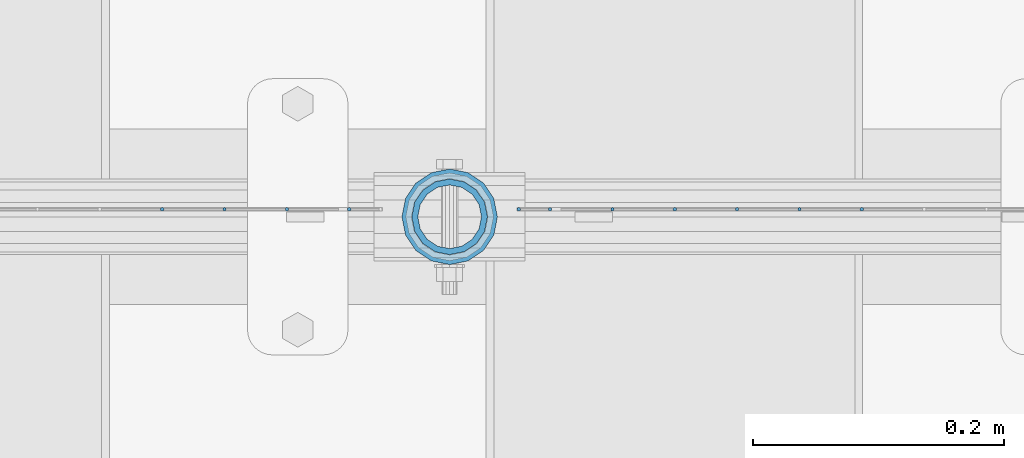
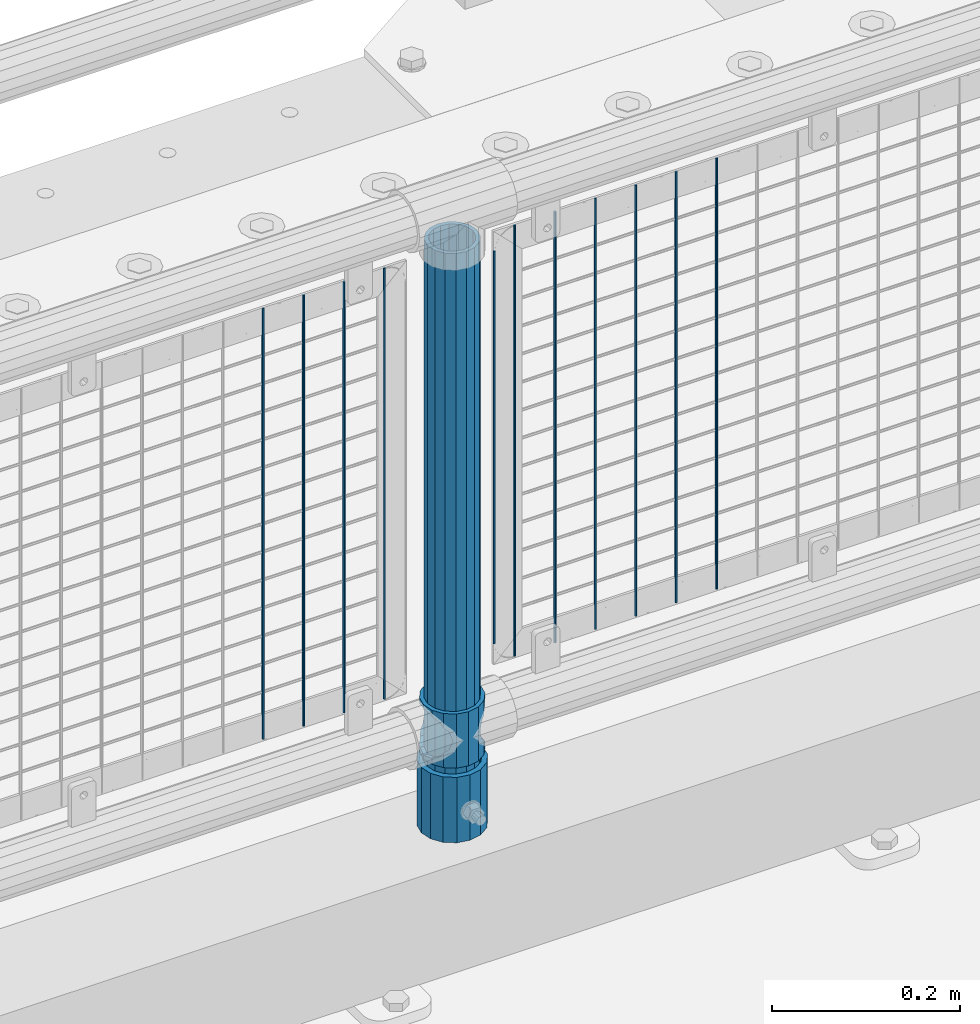
# One storey, part 85 of 247: 14 columns.
"""IFC2X3 building model written with IfcOpenShell, lengths in millimetres."""

import ifcopenshell
import ifcopenshell.guid

model = None  # the IFC model being written
_history = None  # IfcOwnerHistory: only IFC2X3 demands one
_inside = {}  # id of a spatial element -> (the spatial element, [elements in it])
_under = {}  # id of a project, library or spatial element -> (it, [spatial elements below it])
_declared = {}  # id of a project -> (the project, [libraries it declares])
_typed = {}  # id of a type object -> (the type object, [elements of that type])
_made_of = {}  # id of a material, layer set ... -> (it, [elements and type objects made of it])


def new_model(schema):
    """Start an empty IFC model of exactly this schema.

    Asked for "IFC4X3", IfcOpenShell would pick the latest addendum, in which some entities
    have other attributes; the version numbers below select the first issue.
    IFC2X3 requires an IfcOwnerHistory on every rooted entity: one is made here for all.
    """
    global model, _history
    if schema == "IFC4X3":
        model = ifcopenshell.file(schema_version=(4, 3, 0, 0))
    else:
        model = ifcopenshell.file(schema=schema)
    _inside.clear()
    _under.clear()
    _declared.clear()
    _typed.clear()
    _made_of.clear()
    _history = None
    if model.schema == "IFC2X3":
        org = make("IfcOrganization", Name="unknown")
        user = make(
            "IfcPersonAndOrganization",
            ThePerson=make("IfcPerson", FamilyName="unknown"),
            TheOrganization=org,
        )
        app = make(
            "IfcApplication",
            ApplicationDeveloper=org,
            Version="unknown",
            ApplicationFullName="unknown",
            ApplicationIdentifier="unknown",
        )
        _history = make(
            "IfcOwnerHistory",
            OwningUser=user,
            OwningApplication=app,
            ChangeAction="ADDED",
            CreationDate=0,
        )
    return model


def make(cls, **values):
    """One entity of the class cls with the attributes given. An attribute that is None is left unset."""
    return model.create_entity(
        cls, **{name: value for name, value in values.items() if value is not None}
    )


def rooted(cls, **values):
    """An entity with a GlobalId (a new one), such as an element, a storey or a relation."""
    return make(cls, GlobalId=ifcopenshell.guid.new(), OwnerHistory=_history, **values)


def si_unit(unit_type, name, prefix=None):
    """IfcSIUnit, for example si_unit("LENGTHUNIT", "METRE", prefix="MILLI")."""
    return make("IfcSIUnit", UnitType=unit_type, Prefix=prefix, Name=name)


def assignment(units):
    """IfcUnitAssignment: the units of a project."""
    return None if units is None else make("IfcUnitAssignment", Units=units)


def point(xyz):
    """IfcCartesianPoint."""
    return None if xyz is None else make("IfcCartesianPoint", Coordinates=xyz)


def direction(xyz):
    """IfcDirection."""
    return None if xyz is None else make("IfcDirection", DirectionRatios=xyz)


def frame(location, z_axis=None, x_axis=None):
    """IfcAxis2Placement3D, a coordinate frame: its origin and axes. An axis left out is left unset."""
    return make(
        "IfcAxis2Placement3D",
        Location=point(location),
        Axis=direction(z_axis),
        RefDirection=direction(x_axis),
    )


def origin_with_axes():
    """The frame at (0, 0, 0) with the z axis (0, 0, 1) and the x axis (1, 0, 0) written out."""
    return frame((0.0, 0.0, 0.0), z_axis=(0.0, 0.0, 1.0), x_axis=(1.0, 0.0, 0.0))


def place(relative_to, where):
    """IfcLocalPlacement: puts the frame where relative to a parent placement (None: the world)."""
    return make(
        "IfcLocalPlacement", PlacementRelTo=relative_to, RelativePlacement=where
    )


def context(
    kind, dimensions, precision=None, world=None, true_north=None, identifier=None
):
    """IfcGeometricRepresentationContext, for example the 3D "Model" context."""
    return make(
        "IfcGeometricRepresentationContext",
        ContextIdentifier=identifier,
        ContextType=kind,
        CoordinateSpaceDimension=dimensions,
        Precision=precision,
        WorldCoordinateSystem=world,
        TrueNorth=true_north,
    )


def subcontext(parent, identifier, kind, view, scale=None):
    """IfcGeometricRepresentationSubContext, for example "Body" below "Model"."""
    return make(
        "IfcGeometricRepresentationSubContext",
        ContextIdentifier=identifier,
        ContextType=kind,
        ParentContext=parent,
        TargetScale=scale,
        TargetView=view,
    )


def project(units=None, contexts=None):
    """IfcProject with its units and contexts."""
    return rooted(
        "IfcProject",
        Name="project",
        RepresentationContexts=contexts,
        UnitsInContext=assignment(units),
    )


def spatial(cls, under=None, at=None, **own):
    """A site, building, storey or space (cls), placed at a placement, below another one or the project."""
    s = rooted(cls, ObjectPlacement=at, **own)
    if under is not None:
        _under.setdefault(under.id(), (under, []))[1].append(s)
    return s


def faces_of(points, faces, orient=None, outer=None):
    """IfcFace entities. A face is a list of loops; a loop is a list of indices into points, from 0.

    orient and outer hold one flag for each loop. By default every Orientation is true, the
    first loop of a face is its IfcFaceOuterBound and the others are IfcFaceBound.
    """
    made = []
    for i, loops in enumerate(faces):
        bounds = []
        for j, loop in enumerate(loops):
            is_outer = j == 0 if outer is None else outer[i][j]
            bounds.append(
                make(
                    "IfcFaceOuterBound" if is_outer else "IfcFaceBound",
                    Bound=make("IfcPolyLoop", Polygon=[points[k] for k in loop]),
                    Orientation=True if orient is None else orient[i][j],
                )
            )
        made.append(make("IfcFace", Bounds=bounds))
    return made


def faceted_brep(points, faces, orient=None, outer=None, voids=None):
    """IfcFacetedBrep: a solid bounded by flat faces; with voids (closed shells), ...WithVoids."""
    shared = [point(p) for p in points]
    hull = make("IfcClosedShell", CfsFaces=faces_of(shared, faces, orient, outer))
    if voids is None:
        return make("IfcFacetedBrep", Outer=hull)
    return make(
        "IfcFacetedBrepWithVoids",
        Outer=hull,
        Voids=[
            make(cls, CfsFaces=faces_of(shared, fs, o, b)) for cls, fs, o, b in voids
        ],
    )


def shape(context_of_items, identifier, shape_type, items):
    """IfcShapeRepresentation: the items that make up one representation, for example the "Body"."""
    return make(
        "IfcShapeRepresentation",
        ContextOfItems=context_of_items,
        RepresentationIdentifier=identifier,
        RepresentationType=shape_type,
        Items=items,
    )


def material(Name=None, Category=None):
    """IfcMaterial."""
    return make("IfcMaterial", Name=Name, Category=Category)


def made_of(thing, what):
    """Note that an element or type object is made of a material, layer set ...; save() writes the relation."""
    if what is not None:
        _made_of.setdefault(what.id(), (what, []))[1].append(thing)
    return thing


def type_object(cls, material=None, **own):
    """A type object (cls), such as IfcWallType, which elements share."""
    return made_of(rooted(cls, **own), material)


def element(
    cls,
    number,
    at=None,
    inside=None,
    cuts=None,
    type_object=None,
    material=None,
    context=None,
    identifier="Body",
    shape_type=None,
    held_by="IfcProductDefinitionShape",
    body=None,
    shapes=None,
    **own,
):
    """One element of the class cls, such as IfcWall. Its Tag is "e" and its number.

    at: its placement. inside: the storey or other place that contains it. cuts: it is an
    opening in that element (IfcRelVoidsElement). A single representation is given by context,
    identifier, shape_type and body (its items); several are given by shapes. held_by: the class
    of the entity that holds the representations. save() writes the other relations.
    """
    e = rooted(cls, Tag="e%d" % number, ObjectPlacement=at, **own)
    if body is not None:
        shapes = [shape(context, identifier, shape_type, body)]
    if shapes is not None:
        e.Representation = make(held_by, Representations=shapes)
    if inside is not None:
        _inside.setdefault(inside.id(), (inside, []))[1].append(e)
    if cuts is not None:
        rooted(
            "IfcRelVoidsElement", RelatingBuildingElement=cuts, RelatedOpeningElement=e
        )
    if type_object is not None:
        _typed.setdefault(type_object.id(), (type_object, []))[1].append(e)
    return made_of(e, material)


def aggregate(whole, parts):
    """IfcRelAggregates: a whole, such as a stair, and the parts it consists of."""
    return rooted("IfcRelAggregates", RelatingObject=whole, RelatedObjects=parts)


def save(model, path):
    """Write the relations noted so far, then the file.

    IfcRelAggregates (storeys below a building ...), IfcRelContainedInSpatialStructure (elements
    in a storey), IfcRelDefinesByType, IfcRelAssociatesMaterial and IfcRelDeclares: one each for
    every whole, place, type object, material and project.
    """
    for whole, parts in _under.values():
        aggregate(whole, parts)
    for where, things in _inside.values():
        rooted(
            "IfcRelContainedInSpatialStructure",
            RelatedElements=things,
            RelatingStructure=where,
        )
    for kind, things in _typed.values():
        rooted("IfcRelDefinesByType", RelatedObjects=things, RelatingType=kind)
    for what, things in _made_of.values():
        rooted("IfcRelAssociatesMaterial", RelatedObjects=things, RelatingMaterial=what)
    for by, libraries in _declared.values():
        rooted("IfcRelDeclares", RelatingContext=by, RelatedDefinitions=libraries)
    model.write(path)


model = new_model("IFC2X3")

# Units and contexts
model_context = context("Model", 3, precision=1e-05, world=origin_with_axes())
body_context = subcontext(model_context, "Body", "Model", "MODEL_VIEW")
ifc_project = project(units=[si_unit("LENGTHUNIT", "METRE", prefix="MILLI"), si_unit("AREAUNIT", "SQUARE_METRE"), si_unit("VOLUMEUNIT", "CUBIC_METRE"), si_unit("MASSUNIT", "GRAM", prefix="KILO"), si_unit("TIMEUNIT", "SECOND"), si_unit("PLANEANGLEUNIT", "RADIAN"), si_unit("SOLIDANGLEUNIT", "STERADIAN"), si_unit("THERMODYNAMICTEMPERATUREUNIT", "DEGREE_CELSIUS"), si_unit("LUMINOUSINTENSITYUNIT", "LUMEN")], contexts=[model_context])

# Site, building, storey
site_placement = place(None, origin_with_axes())
site = spatial("IfcSite", under=ifc_project, at=site_placement, CompositionType="ELEMENT")
building_placement = place(site_placement, origin_with_axes())
building = spatial("IfcBuilding", under=site, at=building_placement, Name="Standard", CompositionType="ELEMENT")
storey_placement = place(building_placement, origin_with_axes())
storey = spatial("IfcBuildingStorey", under=building, at=storey_placement, Name="Undefined", CompositionType="ELEMENT", Elevation=0.0)

# Columns
ifc_material_1 = material()
column_type_1 = type_object("IfcColumnType", PredefinedType="NOTDEFINED")
column_1_placement = place(storey_placement, frame((8621.0, 7664.5, 168.02), z_axis=(0.0, 1.0, 0.0), x_axis=(0.0, 0.0, 1.0)))
element("IfcColumn", 1, at=column_1_placement, inside=storey, type_object=column_type_1, material=ifc_material_1, context=body_context, shape_type="Brep", body=[
    faceted_brep([(0.0, -31.75, 0.0), (0.0, -29.3331751572332, 12.1501989775916), (85.0, -29.3331751572332, 12.1501989775916), (85.0, -31.75, 0.0), (0.0, -22.4506403026735, 22.4506403026726), (85.0, -22.4506403026735, 22.4506403026726), (0.0, -12.1501989775916, 29.3331751572332), (85.0, -12.1501989775916, 29.3331751572332), (0.0, 0.0, 31.75), (85.0, 0.0, 31.75), (0.0, 12.1501989775916, 29.3331751572332), (85.0, 12.1501989775916, 29.3331751572332), (0.0, 22.4506403026735, 22.4506403026726), (85.0, 22.4506403026735, 22.4506403026726), (0.0, 29.3331751572332, 12.1501989775916), (85.0, 29.3331751572332, 12.1501989775916), (0.0, 31.75, 0.0), (85.0, 31.75, 0.0), (0.0, 29.3331751572332, -12.1501989775916), (85.0, 29.3331751572332, -12.1501989775916), (0.0, 22.4506403026735, -22.4506403026726), (85.0, 22.4506403026735, -22.4506403026726), (0.0, 12.1501989775916, -29.3331751572332), (85.0, 12.1501989775916, -29.3331751572332), (0.0, 0.0, -31.75), (85.0, 0.0, -31.75), (0.0, -12.1501989775916, -29.3331751572332), (85.0, -12.1501989775916, -29.3331751572332), (0.0, -22.4506403026735, -22.4506403026726), (85.0, -22.4506403026735, -22.4506403026726), (0.0, -29.3331751572332, -12.1501989775916), (85.0, -29.3331751572332, -12.1501989775916), (0.0, -38.0499999999993, 0.0), (0.0, -35.1536162120537, -14.5611046014919), (85.0, -35.1536162120537, -14.5611046014919), (85.0, -38.0499999999993, 0.0), (0.0, -26.9054130241475, -26.9054130241484), (85.0, -26.9054130241475, -26.9054130241484), (0.0, -14.561104601491, -35.1536162120547), (85.0, -14.561104601491, -35.1536162120547), (0.0, 0.0, -38.0500000000002), (85.0, 0.0, -38.0500000000002), (0.0, 14.561104601491, -35.1536162120547), (85.0, 14.561104601491, -35.1536162120547), (0.0, 26.9054130241475, -26.9054130241484), (85.0, 26.9054130241475, -26.9054130241484), (0.0, 35.1536162120537, -14.5611046014919), (85.0, 35.1536162120537, -14.5611046014919), (0.0, 38.0499999999993, 0.0), (85.0, 38.0499999999993, 0.0), (0.0, 35.1536162120537, 14.5611046014919), (85.0, 35.1536162120537, 14.5611046014919), (0.0, 26.9054130241475, 26.9054130241484), (85.0, 26.9054130241475, 26.9054130241484), (0.0, 14.561104601491, 35.1536162120547), (85.0, 14.561104601491, 35.1536162120547), (0.0, 0.0, 38.0500000000002), (85.0, 0.0, 38.0500000000002), (0.0, -14.561104601491, 35.1536162120547), (85.0, -14.561104601491, 35.1536162120547), (0.0, -26.9054130241475, 26.9054130241484), (85.0, -26.9054130241475, 26.9054130241484), (0.0, -35.1536162120537, 14.5611046014919), (85.0, -35.1536162120537, 14.5611046014919)], [[[0, 1, 2, 3]], [[1, 4, 5, 2]], [[4, 6, 7, 5]], [[6, 8, 9, 7]], [[8, 10, 11, 9]], [[10, 12, 13, 11]], [[12, 14, 15, 13]], [[14, 16, 17, 15]], [[16, 18, 19, 17]], [[18, 20, 21, 19]], [[20, 22, 23, 21]], [[22, 24, 25, 23]], [[24, 26, 27, 25]], [[26, 28, 29, 27]], [[28, 30, 31, 29]], [[30, 0, 3, 31]], [[32, 33, 34, 35]], [[33, 36, 37, 34]], [[36, 38, 39, 37]], [[38, 40, 41, 39]], [[40, 42, 43, 41]], [[42, 44, 45, 43]], [[44, 46, 47, 45]], [[46, 48, 49, 47]], [[48, 50, 51, 49]], [[50, 52, 53, 51]], [[52, 54, 55, 53]], [[54, 56, 57, 55]], [[56, 58, 59, 57]], [[58, 60, 61, 59]], [[60, 62, 63, 61]], [[62, 32, 35, 63]], [[37, 39, 41, 43, 45, 47, 49, 51, 53, 55, 57, 59, 61, 63, 35, 34], [5, 7, 9, 11, 13, 15, 17, 19, 21, 23, 25, 27, 29, 31, 3, 2]], [[62, 60, 58, 56, 54, 52, 50, 48, 46, 44, 42, 40, 38, 36, 33, 32], [30, 28, 26, 24, 22, 20, 18, 16, 14, 12, 10, 8, 6, 4, 1, 0]]]),
])
ifc_material_2 = material(Name="Misc_Undefined")
column_type_2 = type_object("IfcColumnType", PredefinedType="NOTDEFINED")
column_2_placement = place(storey_placement, frame((8621.0, 7664.5, 263.02), z_axis=(-1.0, 0.0, 0.0), x_axis=(0.0, 0.0, 1.0)))
element("IfcColumn", 2, at=column_2_placement, inside=storey, type_object=column_type_2, material=ifc_material_2, context=body_context, shape_type="Brep", body=[
    faceted_brep([(56.6106908090114, 21.4606908090118, -21.4606908090118), (56.6106908090114, 21.4606908090118, -27.1226768591096), (61.9623795176755, 13.4513226476329, -32.4743655677721), (63.1897438117172, 11.6144421722802, -32.839743811719), (63.1897438117172, 11.6144421722802, -28.0397438117179), (46.7644421722801, 28.0397438117179, -11.6144421722802), (46.7644421722801, 28.0397438117179, -20.088203122983), (51.5310424080055, 24.8548033587067, -24.8548033587067), (35.1499999999996, 30.35, 0.0), (35.1499999999996, 30.3500000000004, -16.6306603983649), (23.5355578277192, 28.0397438117179, -11.6144421722802), (23.5355578277192, 28.0397438117179, -20.088203122983), (13.6893091909879, 21.4606908090118, -21.4606908090118), (13.6893091909879, 21.4606908090118, -27.1226768591096), (18.768957591997, 24.8548033587067, -24.8548033587067), (7.11025618828211, 11.6144421722802, -28.0397438117179), (7.11025618828211, 11.6144421722802, -32.839743811719), (8.33762048232387, 13.4513226476329, -32.4743655677721), (4.79999999999961, 0.0, -30.3500000000004), (4.79999999999961, 0.0, -35.1499999999996), (7.11025618828211, -11.6144421722802, -28.0397438117179), (7.11025618828211, -11.6144421722802, -32.839743811719), (13.6893091909879, -21.4606908090118, -21.4606908090118), (13.6893091909879, -21.4606908090118, -27.1226768591077), (8.33762048232325, -13.4513226476329, -32.4743655677721), (23.5355578277191, -28.0397438117179, -11.6144421722802), (23.5355578277191, -28.0397438117179, -20.0882031229885), (18.768957591997, -24.8548033587067, -24.8548033587067), (35.1499999999996, -30.35, 0.0), (35.1499999999996, -30.3500000000004, -16.6306603983739), (46.7644421722801, -28.0397438117179, -11.6144421722802), (46.7644421722801, -28.0397438117179, -20.0882031229885), (56.6106908090114, -21.4606908090118, -21.4606908090118), (56.6106908090114, -21.4606908090118, -27.1226768591077), (51.5310424080038, -24.8548033587067, -24.8548033587067), (63.1897438117172, -11.6144421722802, -28.0397438117179), (63.1897438117172, -11.6144421722802, -32.839743811719), (61.9623795176754, -13.4513226476329, -32.4743655677721), (65.4999999999997, 0.0, -30.3500000000004), (65.4999999999997, 0.0, -35.1499999999996), (0.0, -28.0397438117179, -11.6144421722802), (0.0, -30.3500000000004, 0.0), (0.0, -21.4606908090118, -21.4606908090118), (0.0, -11.6144421722802, -28.0397438117179), (0.0, 0.0, -30.3500000000004), (0.0, 11.6144421722802, -28.0397438117179), (0.0, 21.4606908090118, -21.4606908090118), (0.0, 28.0397438117179, -11.6144421722802), (0.0, 30.3500000000004, 0.0), (0.0, 28.0397438117179, 11.6144421722802), (23.5355578277192, 28.0397438117179, 11.6144421722806), (0.0, 21.4606908090118, 21.4606908090118), (13.6893091909879, 21.4606908090118, 21.4606908090118), (0.0, 11.6144421722802, 28.0397438117179), (7.11025618828211, 11.6144421722802, 28.0397438117175), (0.0, 0.0, 30.3500000000004), (4.79999999999961, 0.0, 30.3499999999999), (0.0, -11.6144421722802, 28.0397438117179), (7.11025618828205, -11.6144421722802, 28.0397438117175), (0.0, -21.4606908090118, 21.4606908090118), (13.6893091909879, -21.4606908090118, 21.4606908090118), (0.0, -28.0397438117179, 11.6144421722802), (23.5355578277191, -28.0397438117179, 11.6144421722806), (0.0, -32.4743655677721, 13.4513226476338), (0.0, -35.1499999999996, 0.0), (70.2999999999993, -35.1499999999996, 0.0), (70.2999999999993, -32.4743655677721, 13.4513226476338), (0.0, 13.4513226476329, -32.4743655677721), (0.0, 24.8548033587067, -24.8548033587067), (0.0, 0.0, -35.1499999999996), (0.0, -13.4513226476329, -32.4743655677721), (0.0, -24.8548033587067, -24.8548033587067), (0.0, -24.8548033587067, 24.8548033587067), (0.0, -13.4513226476329, 32.4743655677721), (0.0, 0.0, 35.1499999999996), (0.0, 13.4513226476329, 32.4743655677721), (0.0, 24.8548033587067, 24.8548033587067), (0.0, 32.4743655677721, 13.4513226476338), (0.0, 35.1499999999996, 0.0), (0.0, 32.4743655677721, -13.4513226476338), (0.0, -32.4743655677721, -13.4513226476338), (70.2999999999993, 32.4743655677721, 13.4513226476338), (70.2999999999993, 35.1499999999996, 0.0), (70.2999999999993, 32.4743655677721, -13.4513226476338), (70.2999999999993, 24.8548033587067, -24.8548033587067), (70.2999999999993, 13.4513226476329, -32.4743655677721), (70.2999999999993, 0.0, -35.1499999999996), (70.2999999999993, -13.4513226476329, -32.4743655677721), (70.2999999999993, -24.8548033587067, -24.8548033587067), (70.2999999999993, -32.4743655677721, -13.4513226476338), (70.2999999999993, 28.0397438117179, 11.6144421722802), (70.2999999999993, 21.4606908090118, 21.4606908090118), (56.6106908090114, 21.4606908090118, 21.4606908090118), (46.7644421722801, 28.0397438117179, 11.6144421722806), (70.2999999999993, 11.6144421722802, 28.0397438117179), (63.1897438117172, 11.6144421722802, 28.0397438117175), (70.2999999999993, 0.0, 30.3500000000004), (65.4999999999997, 0.0, 30.3499999999999), (70.2999999999993, -11.6144421722802, 28.0397438117179), (63.1897438117172, -11.6144421722802, 28.0397438117175), (70.2999999999993, -21.4606908090118, 21.4606908090118), (56.6106908090114, -21.4606908090118, 21.4606908090118), (70.2999999999993, -28.0397438117179, 11.6144421722802), (46.7644421722801, -28.0397438117179, 11.6144421722806), (70.2999999999993, -11.6144421722802, -28.0397438117179), (70.2999999999993, 0.0, -30.3500000000004), (70.2999999999993, -21.4606908090118, -21.4606908090118), (70.2999999999993, -28.0397438117179, -11.6144421722802), (70.2999999999993, -30.3500000000004, 0.0), (70.2999999999993, 24.8548033587067, 24.8548033587067), (70.2999999999993, 13.4513226476329, 32.4743655677721), (70.2999999999993, 0.0, 35.1499999999996), (70.2999999999993, -13.4513226476329, 32.4743655677721), (70.2999999999993, -24.8548033587067, 24.8548033587067), (70.2999999999993, 30.3500000000004, 0.0), (70.2999999999993, 28.0397438117179, -11.6144421722802), (70.2999999999993, 21.4606908090118, -21.4606908090118), (70.2999999999993, 11.6144421722802, -28.0397438117179), (61.9623795176755, 13.4513226476329, 32.4743655677717), (51.5310424080043, 24.8548033587067, 24.8548033587072), (56.6106908090114, 21.4606908090118, 27.1226768591082), (65.4999999999997, 0.0, 35.1500000000001), (63.1897438117172, 11.6144421722802, 32.8397438117177), (63.1897438117172, -11.6144421722802, 32.8397438117177), (61.962379517675, -13.4513226476329, 32.4743655677717), (56.6106908090114, -21.4606908090118, 27.1226768591068), (51.5310424080026, -24.8548033587067, 24.8548033587072), (18.7689575919956, -24.8548033587067, 24.8548033587072), (46.7644421722801, -28.0397438117179, 20.088203122983), (35.1499999999996, -30.3500000000004, 16.6306603983649), (23.5355578277191, -28.0397438117179, 20.088203122983), (8.33762048232268, -13.4513226476329, 32.4743655677717), (13.6893091909879, -21.4606908090118, 27.1226768591068), (4.79999999999961, 0.0, 35.1500000000001), (7.11025618828205, -11.6144421722802, 32.8397438117177), (7.11025618828211, 11.6144421722802, 32.8397438117177), (8.33762048232427, 13.4513226476329, 32.4743655677717), (13.6893091909879, 21.4606908090118, 27.1226768591082), (18.7689575919966, 24.8548033587067, 24.8548033587072), (23.5355578277192, 28.0397438117179, 20.0882031229844), (35.1499999999996, 30.3500000000004, 16.6306603983667), (46.7644421722801, 28.0397438117179, 20.0882031229844)], [[[0, 1, 2, 3, 4]], [[5, 6, 7, 1, 0]], [[8, 9, 6, 5]], [[10, 11, 9, 8]], [[12, 13, 14, 11, 10]], [[15, 16, 17, 13, 12]], [[18, 19, 16, 15]], [[20, 21, 19, 18]], [[22, 23, 24, 21, 20]], [[25, 26, 27, 23, 22]], [[28, 29, 26, 25]], [[30, 31, 29, 28]], [[32, 33, 34, 31, 30]], [[35, 36, 37, 33, 32]], [[38, 39, 36, 35]], [[4, 3, 39, 38]], [[40, 41, 28, 25]], [[42, 40, 25, 22]], [[43, 42, 22, 20]], [[44, 43, 20, 18]], [[45, 44, 18, 15]], [[46, 45, 15, 12]], [[47, 46, 12, 10]], [[48, 47, 10, 8]], [[49, 48, 8, 50]], [[51, 49, 50, 52]], [[53, 51, 52, 54]], [[55, 53, 54, 56]], [[57, 55, 56, 58]], [[59, 57, 58, 60]], [[61, 59, 60, 62]], [[41, 61, 62, 28]], [[63, 64, 65, 66]], [[17, 67, 68, 14, 13]], [[19, 69, 67, 17, 16]], [[70, 69, 19, 21, 24]], [[71, 70, 24, 23, 27]], [[63, 72, 73, 74, 75, 76, 77, 78, 79, 68, 67, 69, 70, 71, 80, 64], [40, 42, 43, 44, 45, 46, 47, 48, 49, 51, 53, 55, 57, 59, 61, 41]], [[78, 77, 81, 82]], [[79, 78, 82, 83]], [[14, 68, 79, 83, 84, 7, 6, 9, 11]], [[84, 85, 2, 1, 7]], [[85, 86, 39, 3, 2]], [[37, 87, 88, 34, 33]], [[39, 86, 87, 37, 36]], [[34, 88, 89, 80, 71, 27, 26, 29, 31]], [[64, 80, 89, 65]], [[90, 91, 92, 93]], [[91, 94, 95, 92]], [[94, 96, 97, 95]], [[96, 98, 99, 97]], [[98, 100, 101, 99]], [[100, 102, 103, 101]], [[104, 105, 38, 35]], [[106, 104, 35, 32]], [[107, 106, 32, 30]], [[108, 107, 30, 28]], [[102, 108, 28, 103]], [[88, 87, 86, 85, 84, 83, 82, 81, 109, 110, 111, 112, 113, 66, 65, 89], [100, 98, 96, 94, 91, 90, 114, 115, 116, 117, 105, 104, 106, 107, 108, 102]], [[118, 110, 109, 119, 120]], [[121, 111, 110, 118, 122]], [[112, 111, 121, 123, 124]], [[113, 112, 124, 125, 126]], [[127, 72, 63, 66, 113, 126, 128, 129, 130]], [[131, 73, 72, 127, 132]], [[133, 74, 73, 131, 134]], [[75, 74, 133, 135, 136]], [[76, 75, 136, 137, 138]], [[119, 109, 81, 77, 76, 138, 139, 140, 141]], [[92, 120, 119, 141, 93]], [[95, 122, 118, 120, 92]], [[97, 121, 122, 95]], [[99, 123, 121, 97]], [[101, 125, 124, 123, 99]], [[103, 128, 126, 125, 101]], [[28, 129, 128, 103]], [[62, 130, 129, 28]], [[60, 132, 127, 130, 62]], [[58, 134, 131, 132, 60]], [[56, 133, 134, 58]], [[54, 135, 133, 56]], [[52, 137, 136, 135, 54]], [[50, 139, 138, 137, 52]], [[8, 140, 139, 50]], [[93, 141, 140, 8]], [[114, 90, 93, 8]], [[115, 114, 8, 5]], [[116, 115, 5, 0]], [[117, 116, 0, 4]], [[105, 117, 4, 38]]]),
])
column_type_3 = type_object("IfcColumnType", PredefinedType="NOTDEFINED")
column_3_placement = place(storey_placement, frame((8621.0, 7664.5, 168.02), z_axis=(-1.0, 0.0, 0.0), x_axis=(0.0, 0.0, 1.0)))
element("IfcColumn", 3, at=column_3_placement, inside=storey, type_object=column_type_3, material=ifc_material_1, context=body_context, shape_type="Brep", body=[
    faceted_brep([(0.0, -25.3500000000004, 0.0), (0.0, -23.4203461491616, 9.70102501045585), (760.0, -23.4203461491616, 9.70102501045585), (760.0, -25.3500000000004, 0.0), (0.0, -17.9251569030794, 17.9251569030785), (760.0, -17.9251569030794, 17.9251569030785), (0.0, -9.70102501045494, 23.4203461491616), (760.0, -9.70102501045494, 23.4203461491616), (0.0, 0.0, 25.3500000000004), (760.0, 0.0, 25.3500000000004), (0.0, 9.70102501045494, 23.4203461491616), (760.0, 9.70102501045494, 23.4203461491616), (0.0, 17.9251569030794, 17.9251569030785), (760.0, 17.9251569030794, 17.9251569030785), (0.0, 23.4203461491616, 9.70102501045585), (760.0, 23.4203461491616, 9.70102501045585), (0.0, 25.3500000000004, 0.0), (760.0, 25.3500000000004, 0.0), (0.0, 23.4203461491616, -9.70102501045585), (760.0, 23.4203461491616, -9.70102501045585), (0.0, 17.9251569030794, -17.9251569030785), (760.0, 17.9251569030794, -17.9251569030785), (0.0, 9.70102501045494, -23.4203461491616), (760.0, 9.70102501045494, -23.4203461491616), (0.0, 0.0, -25.3500000000004), (760.0, 0.0, -25.3500000000004), (0.0, -9.70102501045494, -23.4203461491616), (760.0, -9.70102501045494, -23.4203461491616), (0.0, -17.9251569030794, -17.9251569030785), (760.0, -17.9251569030794, -17.9251569030785), (0.0, -23.4203461491616, -9.70102501045585), (760.0, -23.4203461491616, -9.70102501045585), (0.0, -30.1499999999996, 0.0), (0.0, -27.8549679052148, -11.5379054858076), (760.0, -27.8549679052148, -11.5379054858076), (760.0, -30.1499999999996, 0.0), (0.0, -21.3192694527743, -21.3192694527752), (760.0, -21.3192694527743, -21.3192694527752), (0.0, -11.5379054858076, -27.8549679052157), (760.0, -11.5379054858076, -27.8549679052157), (0.0, 0.0, -30.1499999999996), (760.0, 0.0, -30.1499999999996), (0.0, 11.5379054858076, -27.8549679052157), (760.0, 11.5379054858076, -27.8549679052157), (0.0, 21.3192694527743, -21.3192694527752), (760.0, 21.3192694527743, -21.3192694527752), (0.0, 27.8549679052157, -11.5379054858076), (760.0, 27.8549679052157, -11.5379054858076), (0.0, 30.1499999999996, 0.0), (760.0, 30.1499999999996, 0.0), (0.0, 27.8549679052157, 11.5379054858076), (760.0, 27.8549679052157, 11.5379054858076), (0.0, 21.3192694527743, 21.3192694527752), (760.0, 21.3192694527743, 21.3192694527752), (0.0, 11.5379054858076, 27.8549679052157), (760.0, 11.5379054858076, 27.8549679052157), (0.0, 0.0, 30.1499999999996), (760.0, 0.0, 30.1499999999996), (0.0, -11.5379054858076, 27.8549679052157), (760.0, -11.5379054858076, 27.8549679052157), (0.0, -21.3192694527743, 21.3192694527752), (760.0, -21.3192694527743, 21.3192694527752), (0.0, -27.8549679052157, 11.5379054858076), (760.0, -27.8549679052157, 11.5379054858076)], [[[0, 1, 2, 3]], [[1, 4, 5, 2]], [[4, 6, 7, 5]], [[6, 8, 9, 7]], [[8, 10, 11, 9]], [[10, 12, 13, 11]], [[12, 14, 15, 13]], [[14, 16, 17, 15]], [[16, 18, 19, 17]], [[18, 20, 21, 19]], [[20, 22, 23, 21]], [[22, 24, 25, 23]], [[24, 26, 27, 25]], [[26, 28, 29, 27]], [[28, 30, 31, 29]], [[30, 0, 3, 31]], [[32, 33, 34, 35]], [[33, 36, 37, 34]], [[36, 38, 39, 37]], [[38, 40, 41, 39]], [[40, 42, 43, 41]], [[42, 44, 45, 43]], [[44, 46, 47, 45]], [[46, 48, 49, 47]], [[48, 50, 51, 49]], [[50, 52, 53, 51]], [[52, 54, 55, 53]], [[54, 56, 57, 55]], [[56, 58, 59, 57]], [[58, 60, 61, 59]], [[60, 62, 63, 61]], [[62, 32, 35, 63]], [[37, 39, 41, 43, 45, 47, 49, 51, 53, 55, 57, 59, 61, 63, 35, 34], [5, 7, 9, 11, 13, 15, 17, 19, 21, 23, 25, 27, 29, 31, 3, 2]], [[62, 60, 58, 56, 54, 52, 50, 48, 46, 44, 42, 40, 38, 36, 33, 32], [30, 28, 26, 24, 22, 20, 18, 16, 14, 12, 10, 8, 6, 4, 1, 0]]]),
])
column_type_4 = type_object("IfcColumnType", Name="D3", PredefinedType="NOTDEFINED")
for number, where, z_axis, x_axis in (
    (4, (8949.275, 7670.5, 353.020000000003), (-1.0, 0.0, 0.0), (0.0, 0.0, 1.0)),
    (5, (8899.62, 7670.5, 353.020000000003), (-1.0, 0.0, 0.0), (0.0, 0.0, 1.0)),
    (6, (8849.965, 7670.5, 353.020000000003), (-1.0, 0.0, 0.0), (0.0, 0.0, 1.0)),
    (7, (8800.31034482759, 7670.5, 353.020000000003), (-1.0, 0.0, 0.0), (0.0, 0.0, 1.0)),
    (8, (8750.65517241379, 7670.5, 353.020000000003), (-0.999999999962839, 0.0, 8.62099999968473e-06), (8.62099999949798e-06, 0.0, 0.999999999962839)),
):
    element("IfcColumn", number, at=place(storey_placement, frame(where, z_axis=z_axis, x_axis=x_axis)), inside=storey, type_object=column_type_4, material=ifc_material_2, ObjectType="D3", context=body_context, shape_type="Brep", body=[
        faceted_brep([(1.81898940354586e-12, -1.5, -5.6843418860808e-14), (0.0, -0.75, -1.29903810567703), (560.0, -0.75, -1.29903810567703), (560.0, -1.5, 0.0), (0.0, 0.75, -1.29903810567703), (560.0, 0.75, -1.29903810567703), (1.81898940354586e-12, 1.5, -5.6843418860808e-14), (560.0, 1.5, 0.0), (0.0, 0.75, 1.29903810567703), (560.0, 0.75, 1.29903810567703), (0.0, -0.75, 1.29903810567703), (560.0, -0.75, 1.29903810567703)], [[[0, 1, 2, 3]], [[1, 4, 5, 2]], [[4, 6, 7, 5]], [[6, 8, 9, 7]], [[8, 10, 11, 9]], [[10, 0, 3, 11]], [[5, 7, 9, 11, 3, 2]], [[10, 8, 6, 4, 1, 0]]]),
    ])
column_4_placement = place(storey_placement, frame((8676.0, 7670.5, 378.020000000003), z_axis=(-1.0, 0.0, 0.0), x_axis=(0.0, 0.0, 1.0)))
element("IfcColumn", 9, at=column_4_placement, inside=storey, type_object=column_type_4, material=ifc_material_2, ObjectType="D3", context=body_context, shape_type="Brep", body=[
    faceted_brep([(1.81898940354586e-12, -1.5, -5.6843418860808e-14), (0.0, -0.75, -1.29903810567703), (510.0, -0.75, -1.29903810567703), (510.0, -1.5, 0.0), (0.0, 0.75, -1.29903810567703), (510.0, 0.75, -1.29903810567703), (1.81898940354586e-12, 1.5, -5.6843418860808e-14), (510.0, 1.5, 0.0), (0.0, 0.75, 1.29903810567703), (510.0, 0.75, 1.29903810567703), (0.0, -0.75, 1.29903810567703), (510.0, -0.75, 1.29903810567703)], [[[0, 1, 2, 3]], [[1, 4, 5, 2]], [[4, 6, 7, 5]], [[6, 8, 9, 7]], [[8, 10, 11, 9]], [[10, 0, 3, 11]], [[5, 7, 9, 11, 3, 2]], [[10, 8, 6, 4, 1, 0]]]),
])
for number, where, z_axis, x_axis in (
    (10, (8701.0, 7670.5, 353.020000000003), (-1.0, 0.0, 0.0), (0.0, 0.0, 1.0)),
    (11, (8540.995, 7670.50000000001, 353.020000000002), (-1.0, 0.0, 0.0), (0.0, 0.0, 1.0)),
    (12, (8491.34, 7670.50000000001, 353.020000000002), (-1.0, 0.0, 0.0), (0.0, 0.0, 1.0)),
    (13, (8441.685, 7670.50000000001, 353.020000000002), (-1.0, 0.0, 0.0), (0.0, 0.0, 1.0)),
    (14, (8392.03, 7670.50000000001, 353.020000000002), (-1.0, 0.0, 0.0), (0.0, 0.0, 1.0)),
):
    element("IfcColumn", number, at=place(storey_placement, frame(where, z_axis=z_axis, x_axis=x_axis)), inside=storey, type_object=column_type_4, material=ifc_material_2, ObjectType="D3", context=body_context, shape_type="Brep", body=[
        faceted_brep([(1.81898940354586e-12, -1.5, -5.6843418860808e-14), (0.0, -0.75, -1.29903810567703), (560.0, -0.75, -1.29903810567703), (560.0, -1.5, 0.0), (0.0, 0.75, -1.29903810567703), (560.0, 0.75, -1.29903810567703), (1.81898940354586e-12, 1.5, -5.6843418860808e-14), (560.0, 1.5, 0.0), (0.0, 0.75, 1.29903810567703), (560.0, 0.75, 1.29903810567703), (0.0, -0.75, 1.29903810567703), (560.0, -0.75, 1.29903810567703)], [[[0, 1, 2, 3]], [[1, 4, 5, 2]], [[4, 6, 7, 5]], [[6, 8, 9, 7]], [[8, 10, 11, 9]], [[10, 0, 3, 11]], [[5, 7, 9, 11, 3, 2]], [[10, 8, 6, 4, 1, 0]]]),
    ])

save(model, "model.ifc")
